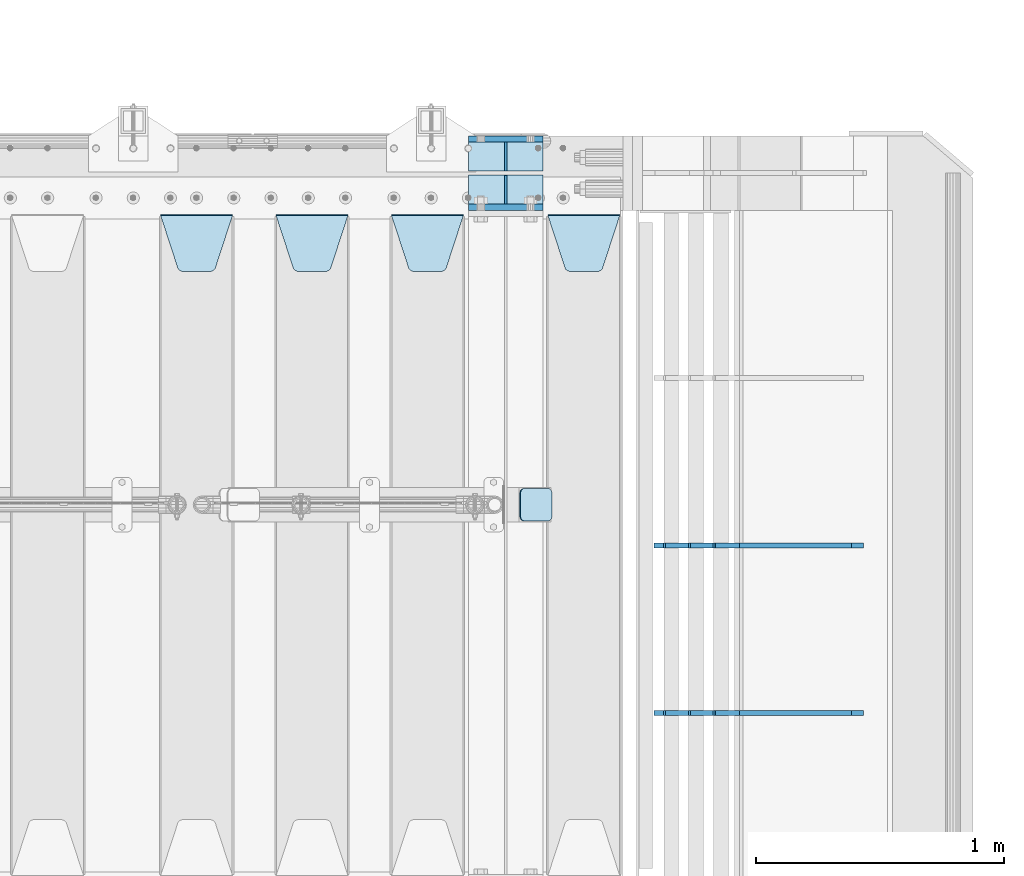
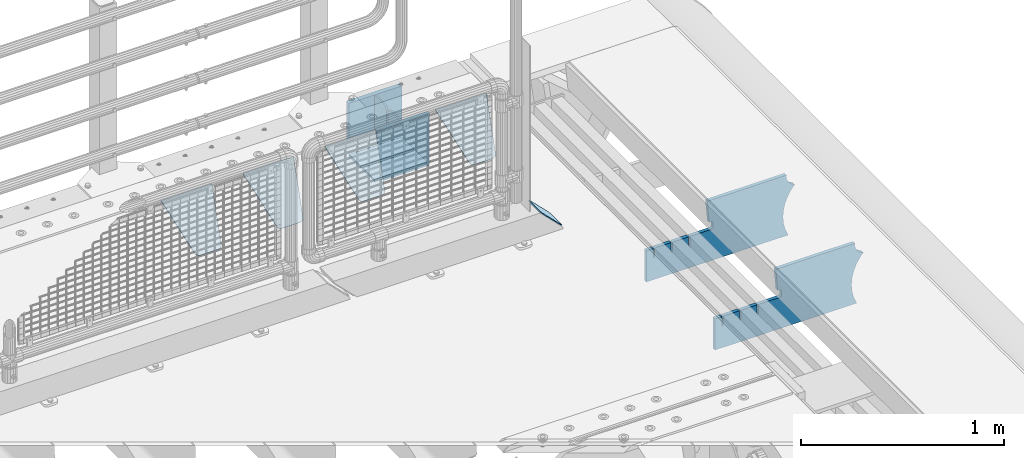
# One storey, part 242 of 257: 13 plates.
"""IFC2X3 building model written with IfcOpenShell, lengths in millimetres."""

from ifc_helpers import new_model, si_unit, frame, origin_with_axes, place, context, subcontext, project, spatial, faceted_brep, material, type_object, element, save


model = new_model("IFC2X3")

# Units and contexts
model_context = context("Model", 3, precision=1e-05, world=origin_with_axes())
body_context = subcontext(model_context, "Body", "Model", "MODEL_VIEW")
ifc_project = project(units=[si_unit("LENGTHUNIT", "METRE", prefix="MILLI"), si_unit("AREAUNIT", "SQUARE_METRE"), si_unit("VOLUMEUNIT", "CUBIC_METRE"), si_unit("MASSUNIT", "GRAM", prefix="KILO"), si_unit("TIMEUNIT", "SECOND"), si_unit("PLANEANGLEUNIT", "RADIAN"), si_unit("SOLIDANGLEUNIT", "STERADIAN"), si_unit("THERMODYNAMICTEMPERATUREUNIT", "DEGREE_CELSIUS"), si_unit("LUMINOUSINTENSITYUNIT", "LUMEN")], contexts=[model_context])

# Site, building, storey
site_placement = place(None, origin_with_axes())
site = spatial("IfcSite", under=ifc_project, at=site_placement, CompositionType="ELEMENT")
building_placement = place(site_placement, origin_with_axes())
building = spatial("IfcBuilding", under=site, at=building_placement, Name="Standard", CompositionType="ELEMENT")
storey_placement = place(building_placement, origin_with_axes())
storey = spatial("IfcBuildingStorey", under=building, at=storey_placement, Name="Undefined", CompositionType="ELEMENT", Elevation=0.0)

# Plates
ifc_material_1 = material(Name="STEEL/S355N")
plate_type_1 = type_object("IfcPlateType", PredefinedType="NOTDEFINED")
for number, where, z_axis, x_axis in (
    (1, (58645.0, 12137.5, -339.999999999993), (0.0, 0.0, 1.0), (1.0, 0.0, 0.0)),
    (2, (58645.0, 11862.5, -339.999999999993), (0.0, 0.0, 1.0), (1.0, 0.0, 0.0)),
):
    element("IfcPlate", number, at=place(storey_placement, frame(where, z_axis=z_axis, x_axis=x_axis)), inside=storey, type_object=plate_type_1, material=ifc_material_1, context=body_context, shape_type="Brep", body=[
        faceted_brep([(0.0, -12.5, 0.0), (0.0, -12.5, 310.0), (0.0, 12.5, 310.0), (0.0, 12.5, 0.0), (300.0, -12.5, 310.0), (300.0, 12.5, 310.0), (300.0, -12.5, 0.0), (300.0, 12.5, 0.0)], [[[0, 1, 2, 3]], [[1, 4, 5, 2]], [[4, 6, 7, 5]], [[6, 0, 3, 7]], [[5, 7, 3, 2]], [[6, 4, 1, 0]]]),
    ])
plate_type_2 = type_object("IfcPlateType", PredefinedType="NOTDEFINED")
for number, where, z_axis, x_axis in (
    (3, (58645.0, 11992.0, -342.999999999993), (0.0, -1.0, 0.0), (1.0, 0.0, 0.0)),
    (4, (58645.0, 12008.0, -342.999999999993), (0.0, 1.0, 0.0), (1.0, 0.0, 0.0)),
):
    element("IfcPlate", number, at=place(storey_placement, frame(where, z_axis=z_axis, x_axis=x_axis)), inside=storey, type_object=plate_type_2, material=ifc_material_1, context=body_context, shape_type="Brep", body=[
        faceted_brep([(0.0, -7.0, 0.0), (0.0, -7.0, 117.0), (0.0, 7.0, 117.0), (0.0, 7.0, 0.0), (300.0, -7.0, 117.0), (300.0, 7.0, 117.0), (300.0, -7.0, 0.0), (300.0, 7.0, 0.0)], [[[0, 1, 2, 3]], [[1, 4, 5, 2]], [[4, 6, 7, 5]], [[6, 0, 3, 7]], [[5, 7, 3, 2]], [[6, 4, 1, 0]]]),
    ])
plate_type_3 = type_object("IfcPlateType", PredefinedType="NOTDEFINED")
for number, where, z_axis, x_axis in (
    (5, (58795.0, 12008.0, -29.999999999993), (0.0, 0.0, -1.0), (0.0, 1.0, 0.0)),
    (6, (58795.0, 11992.0, -29.999999999993), (0.0, 0.0, -1.0), (0.0, -1.0, 0.0)),
):
    element("IfcPlate", number, at=place(storey_placement, frame(where, z_axis=z_axis, x_axis=x_axis)), inside=storey, type_object=plate_type_3, material=ifc_material_1, context=body_context, shape_type="Brep", body=[
        faceted_brep([(0.0, -5.0, 30.0), (0.0, -5.0, 306.0), (0.0, 5.0, 306.0), (0.0, 5.0, 30.0), (117.0, -5.0, 306.0), (117.0, 5.0, 306.0), (117.0, -5.0, 0.0), (117.0, 5.0, 0.0), (30.0, -5.0, 0.0), (30.0, 5.0, 0.0), (24.7905546699922, -5.0, 0.455767409633758), (24.7905546699922, 5.0, 0.455767409633758), (19.7393957002296, -5.0, 1.80922137642275), (19.7393957002296, 5.0, 1.80922137642275), (15.0, -5.0, 4.01923788646684), (15.0, 5.0, 4.01923788646684), (10.7163717094036, -5.0, 7.01866670643066), (10.7163717094036, 5.0, 7.01866670643066), (7.01866670643085, -5.0, 10.7163717094038), (7.01866670643085, 5.0, 10.7163717094038), (4.01923788646673, -5.0, 15.0), (4.01923788646673, 5.0, 15.0), (1.80922137642301, -5.0, 19.7393957002299), (1.80922137642301, 5.0, 19.7393957002299), (0.455767409634063, -5.0, 24.7905546699921), (0.455767409634063, 5.0, 24.7905546699921)], [[[0, 1, 2, 3]], [[1, 4, 5, 2]], [[4, 6, 7, 5]], [[6, 8, 9, 7]], [[8, 10, 11, 9]], [[10, 12, 13, 11]], [[12, 14, 15, 13]], [[14, 16, 17, 15]], [[16, 18, 19, 17]], [[18, 20, 21, 19]], [[20, 22, 23, 21]], [[22, 24, 25, 23]], [[24, 0, 3, 25]], [[5, 7, 9, 11, 13, 15, 17, 19, 21, 23, 25, 3, 2]], [[24, 22, 20, 18, 16, 14, 12, 10, 8, 6, 4, 1, 0]]]),
    ])
plate_type_4 = type_object("IfcPlateType", PredefinedType="NOTDEFINED")
plate_1_placement = place(storey_placement, frame((58965.0, 11831.7677669559, -1.767766952965), z_axis=(0.0, -0.707106781186548, -0.707106781186547), x_axis=(1.0, 0.0, 0.0)))
element("IfcPlate", 7, at=plate_1_placement, inside=storey, type_object=plate_type_4, material=ifc_material_1, context=body_context, shape_type="Brep", body=[
    faceted_brep([(0.0, -2.5, 0.0), (69.345504679477, -2.50000000000091, 300.17173142483), (69.345504679477, 2.5, 300.171731424831), (0.0, 2.5, 0.0), (70.927406119954, -2.50000000000091, 304.8974424154), (70.927406119954, 2.5, 304.8974424154), (73.3818627772271, -2.50000000000091, 309.234538108527), (73.3818627772271, 2.49999999999909, 309.234538108527), (76.6187032999587, -2.5, 313.023683126103), (76.6187032999587, 2.5, 313.023683126103), (80.5190132705029, -2.5, 316.125672595372), (80.5190132705029, 2.5, 316.125672595371), (84.9395038596849, -2.5, 318.426546230476), (84.9395038596849, 2.5, 318.426546230477), (89.7177759439219, -2.5, 319.841774983275), (89.7177759439219, 2.5, 319.841774983275), (94.6782862926484, -2.5, 320.319366455079), (94.6782862926484, 2.5, 320.319366455079), (195.321713707352, -2.5, 320.319366455079), (195.321713707352, 2.5, 320.319366455079), (200.282224056078, -2.5, 319.841774983275), (200.282224056078, 2.49999999999909, 319.841774983275), (205.060496140315, -2.5, 318.426546230476), (205.060496140315, 2.49999999999909, 318.426546230475), (209.480986729497, -2.5, 316.125672595371), (209.480986729497, 2.5, 316.125672595371), (213.381296700041, -2.50000000000091, 313.023683126102), (213.381296700041, 2.5, 313.023683126103), (216.618137222766, -2.50000000000091, 309.234538108527), (216.618137222766, 2.5, 309.234538108527), (219.072593880039, -2.5, 304.897442415399), (219.072593880039, 2.5, 304.897442415399), (220.654495320523, -2.50000000000091, 300.17173142483), (220.654495320523, 2.5, 300.171731424831), (290.0, -2.50000000000091, 0.0), (290.0, 2.5, 9.09494701772928e-13)], [[[0, 1, 2, 3]], [[1, 4, 5, 2]], [[4, 6, 7, 5]], [[6, 8, 9, 7]], [[8, 10, 11, 9]], [[10, 12, 13, 11]], [[12, 14, 15, 13]], [[14, 16, 17, 15]], [[16, 18, 19, 17]], [[18, 20, 21, 19]], [[20, 22, 23, 21]], [[22, 24, 25, 23]], [[24, 26, 27, 25]], [[26, 28, 29, 27]], [[28, 30, 31, 29]], [[30, 32, 33, 31]], [[32, 34, 35, 33]], [[34, 0, 3, 35]], [[5, 7, 9, 11, 13, 15, 17, 19, 21, 23, 25, 27, 29, 31, 33, 35, 3, 2]], [[34, 32, 30, 28, 26, 24, 22, 20, 18, 16, 14, 12, 10, 8, 6, 4, 1, 0]]]),
])
plate_2_placement = place(storey_placement, frame((58335.0, 11831.7677669559, -1.767766952965), z_axis=(0.0, -0.707106781186548, -0.707106781186547), x_axis=(1.0, 0.0, 0.0)))
element("IfcPlate", 8, at=plate_2_placement, inside=storey, type_object=plate_type_4, material=ifc_material_1, context=body_context, shape_type="Brep", body=[
    faceted_brep([(0.0, -2.5, 0.0), (69.345504679477, -2.50000000000091, 300.17173142483), (69.345504679477, 2.5, 300.171731424831), (0.0, 2.5, 0.0), (70.927406119954, -2.50000000000091, 304.8974424154), (70.927406119954, 2.5, 304.8974424154), (73.3818627772271, -2.50000000000091, 309.234538108527), (73.3818627772271, 2.49999999999909, 309.234538108527), (76.6187032999587, -2.5, 313.023683126103), (76.6187032999587, 2.5, 313.023683126103), (80.5190132705029, -2.5, 316.125672595372), (80.5190132705029, 2.5, 316.125672595371), (84.9395038596849, -2.5, 318.426546230476), (84.9395038596849, 2.5, 318.426546230477), (89.7177759439219, -2.5, 319.841774983275), (89.7177759439219, 2.5, 319.841774983275), (94.6782862926484, -2.5, 320.319366455079), (94.6782862926484, 2.5, 320.319366455079), (195.321713707352, -2.5, 320.319366455079), (195.321713707352, 2.5, 320.319366455079), (200.282224056078, -2.5, 319.841774983275), (200.282224056078, 2.49999999999909, 319.841774983275), (205.060496140315, -2.5, 318.426546230476), (205.060496140315, 2.49999999999909, 318.426546230475), (209.480986729497, -2.5, 316.125672595371), (209.480986729497, 2.5, 316.125672595371), (213.381296700041, -2.50000000000091, 313.023683126102), (213.381296700041, 2.5, 313.023683126103), (216.618137222766, -2.50000000000091, 309.234538108527), (216.618137222766, 2.5, 309.234538108527), (219.072593880039, -2.5, 304.897442415399), (219.072593880039, 2.5, 304.897442415399), (220.654495320523, -2.50000000000091, 300.17173142483), (220.654495320523, 2.5, 300.171731424831), (290.0, -2.50000000000091, 0.0), (290.0, 2.5, 9.09494701772928e-13)], [[[0, 1, 2, 3]], [[1, 4, 5, 2]], [[4, 6, 7, 5]], [[6, 8, 9, 7]], [[8, 10, 11, 9]], [[10, 12, 13, 11]], [[12, 14, 15, 13]], [[14, 16, 17, 15]], [[16, 18, 19, 17]], [[18, 20, 21, 19]], [[20, 22, 23, 21]], [[22, 24, 25, 23]], [[24, 26, 27, 25]], [[26, 28, 29, 27]], [[28, 30, 31, 29]], [[30, 32, 33, 31]], [[32, 34, 35, 33]], [[34, 0, 3, 35]], [[5, 7, 9, 11, 13, 15, 17, 19, 21, 23, 25, 27, 29, 31, 33, 35, 3, 2]], [[34, 32, 30, 28, 26, 24, 22, 20, 18, 16, 14, 12, 10, 8, 6, 4, 1, 0]]]),
])
plate_3_placement = place(storey_placement, frame((57870.0, 11831.7677669559, -1.767766952965), z_axis=(0.0, -0.707106781186548, -0.707106781186547), x_axis=(1.0, 0.0, 0.0)))
element("IfcPlate", 9, at=plate_3_placement, inside=storey, type_object=plate_type_4, material=ifc_material_1, context=body_context, shape_type="Brep", body=[
    faceted_brep([(0.0, -2.5, 0.0), (69.345504679477, -2.50000000000091, 300.17173142483), (69.345504679477, 2.5, 300.171731424831), (0.0, 2.5, 0.0), (70.927406119954, -2.50000000000091, 304.8974424154), (70.927406119954, 2.5, 304.8974424154), (73.3818627772271, -2.50000000000091, 309.234538108527), (73.3818627772271, 2.49999999999909, 309.234538108527), (76.6187032999587, -2.5, 313.023683126103), (76.6187032999587, 2.5, 313.023683126103), (80.5190132705029, -2.5, 316.125672595372), (80.5190132705029, 2.5, 316.125672595371), (84.9395038596849, -2.5, 318.426546230476), (84.9395038596849, 2.5, 318.426546230477), (89.7177759439219, -2.5, 319.841774983275), (89.7177759439219, 2.5, 319.841774983275), (94.6782862926484, -2.5, 320.319366455079), (94.6782862926484, 2.5, 320.319366455079), (195.321713707352, -2.5, 320.319366455079), (195.321713707352, 2.5, 320.319366455079), (200.282224056078, -2.5, 319.841774983275), (200.282224056078, 2.49999999999909, 319.841774983275), (205.060496140315, -2.5, 318.426546230476), (205.060496140315, 2.49999999999909, 318.426546230475), (209.480986729497, -2.5, 316.125672595371), (209.480986729497, 2.5, 316.125672595371), (213.381296700041, -2.50000000000091, 313.023683126102), (213.381296700041, 2.5, 313.023683126103), (216.618137222766, -2.50000000000091, 309.234538108527), (216.618137222766, 2.5, 309.234538108527), (219.072593880039, -2.5, 304.897442415399), (219.072593880039, 2.5, 304.897442415399), (220.654495320523, -2.50000000000091, 300.17173142483), (220.654495320523, 2.5, 300.171731424831), (290.0, -2.50000000000091, 0.0), (290.0, 2.5, 9.09494701772928e-13)], [[[0, 1, 2, 3]], [[1, 4, 5, 2]], [[4, 6, 7, 5]], [[6, 8, 9, 7]], [[8, 10, 11, 9]], [[10, 12, 13, 11]], [[12, 14, 15, 13]], [[14, 16, 17, 15]], [[16, 18, 19, 17]], [[18, 20, 21, 19]], [[20, 22, 23, 21]], [[22, 24, 25, 23]], [[24, 26, 27, 25]], [[26, 28, 29, 27]], [[28, 30, 31, 29]], [[30, 32, 33, 31]], [[32, 34, 35, 33]], [[34, 0, 3, 35]], [[5, 7, 9, 11, 13, 15, 17, 19, 21, 23, 25, 27, 29, 31, 33, 35, 3, 2]], [[34, 32, 30, 28, 26, 24, 22, 20, 18, 16, 14, 12, 10, 8, 6, 4, 1, 0]]]),
])
plate_4_placement = place(storey_placement, frame((57405.0, 11831.7677669559, -1.767766952965), z_axis=(0.0, -0.707106781186548, -0.707106781186547), x_axis=(1.0, 0.0, 0.0)))
element("IfcPlate", 10, at=plate_4_placement, inside=storey, type_object=plate_type_4, material=ifc_material_1, context=body_context, shape_type="Brep", body=[
    faceted_brep([(0.0, -2.5, 0.0), (69.345504679477, -2.50000000000091, 300.17173142483), (69.345504679477, 2.5, 300.171731424831), (0.0, 2.5, 0.0), (70.927406119954, -2.50000000000091, 304.8974424154), (70.927406119954, 2.5, 304.8974424154), (73.3818627772271, -2.50000000000091, 309.234538108527), (73.3818627772271, 2.49999999999909, 309.234538108527), (76.6187032999587, -2.5, 313.023683126103), (76.6187032999587, 2.5, 313.023683126103), (80.5190132705029, -2.5, 316.125672595372), (80.5190132705029, 2.5, 316.125672595371), (84.9395038596849, -2.5, 318.426546230476), (84.9395038596849, 2.5, 318.426546230477), (89.7177759439219, -2.5, 319.841774983275), (89.7177759439219, 2.5, 319.841774983275), (94.6782862926484, -2.5, 320.319366455079), (94.6782862926484, 2.5, 320.319366455079), (195.321713707352, -2.5, 320.319366455079), (195.321713707352, 2.5, 320.319366455079), (200.282224056078, -2.5, 319.841774983275), (200.282224056078, 2.49999999999909, 319.841774983275), (205.060496140315, -2.5, 318.426546230476), (205.060496140315, 2.49999999999909, 318.426546230475), (209.480986729497, -2.5, 316.125672595371), (209.480986729497, 2.5, 316.125672595371), (213.381296700041, -2.50000000000091, 313.023683126102), (213.381296700041, 2.5, 313.023683126103), (216.618137222766, -2.50000000000091, 309.234538108527), (216.618137222766, 2.5, 309.234538108527), (219.072593880039, -2.5, 304.897442415399), (219.072593880039, 2.5, 304.897442415399), (220.654495320523, -2.50000000000091, 300.17173142483), (220.654495320523, 2.5, 300.171731424831), (290.0, -2.50000000000091, 0.0), (290.0, 2.5, 9.09494701772928e-13)], [[[0, 1, 2, 3]], [[1, 4, 5, 2]], [[4, 6, 7, 5]], [[6, 8, 9, 7]], [[8, 10, 11, 9]], [[10, 12, 13, 11]], [[12, 14, 15, 13]], [[14, 16, 17, 15]], [[16, 18, 19, 17]], [[18, 20, 21, 19]], [[20, 22, 23, 21]], [[22, 24, 25, 23]], [[24, 26, 27, 25]], [[26, 28, 29, 27]], [[28, 30, 31, 29]], [[30, 32, 33, 31]], [[32, 34, 35, 33]], [[34, 0, 3, 35]], [[5, 7, 9, 11, 13, 15, 17, 19, 21, 23, 25, 27, 29, 31, 33, 35, 3, 2]], [[34, 32, 30, 28, 26, 24, 22, 20, 18, 16, 14, 12, 10, 8, 6, 4, 1, 0]]]),
])
ifc_material_2 = material(Name="STEEL/S355J2")
plate_type_5 = type_object("IfcPlateType", PredefinedType="NOTDEFINED")
plate_5_placement = place(storey_placement, frame((58853.192418479, 10729.5, 166.254400376571), z_axis=(0.707410512925779, 0.0, -0.70680291892584), x_axis=(0.0, -1.0, 0.0)))
element("IfcPlate", 11, at=plate_5_placement, inside=storey, type_object=plate_type_5, material=ifc_material_2, context=body_context, shape_type="Brep", body=[
    faceted_brep([(0.0, -2.49999999999272, 19.9999999999927), (0.0, -2.49999999999272, 158.926651000977), (0.0, 2.50000000001455, 158.926651000969), (0.0, 2.50000000000728, 19.9999999999927), (0.384294391935327, -2.49999999999272, 162.828457441297), (0.384294391935327, 2.50000000000728, 162.828457441297), (1.52240934977453, -2.49999999999272, 166.580319648267), (1.52240934977453, 2.50000000000728, 166.580319648267), (3.37060775394821, -2.5, 170.03805566136), (3.37060775394821, 2.50000000000728, 170.03805566136), (5.85786437626848, -2.49999999999272, 173.068786624703), (5.85786437626848, 2.5, 173.068786624703), (8.88859533960749, -2.49999999999272, 175.556043247016), (8.88859533960749, 2.50000000001455, 175.556043247016), (12.3463313526991, -2.49999999999272, 177.404241651195), (12.3463313526991, 2.50000000000728, 177.404241651195), (16.0981935596774, -2.49999999999272, 178.542356609032), (16.0981935596774, 2.50000000000728, 178.542356609032), (20.0, -2.49999999999272, 178.926651000969), (20.0, 2.50000000000728, 178.926651000969), (110.0, -2.49999999999272, 178.926651000969), (110.0, 2.50000000000728, 178.926651000969), (113.901806440323, -2.49999999999272, 178.542356609032), (113.901806440323, 2.50000000000728, 178.542356609032), (117.653668647301, -2.49999999999272, 177.404241651195), (117.653668647301, 2.50000000000728, 177.404241651195), (121.111404660393, -2.49999999999272, 175.556043247016), (121.111404660393, 2.50000000001455, 175.556043247016), (124.142135623732, -2.49999999999272, 173.068786624703), (124.142135623732, 2.5, 173.068786624703), (126.629392246052, -2.5, 170.03805566136), (126.629392246052, 2.50000000000728, 170.03805566136), (128.477590650225, -2.49999999999272, 166.580319648267), (128.477590650225, 2.50000000000728, 166.580319648267), (129.615705608065, -2.49999999999272, 162.828457441297), (129.615705608065, 2.50000000000728, 162.828457441297), (130.0, -2.49999999999272, 158.926651000977), (130.0, 2.50000000001455, 158.926651000969), (130.0, -2.49999999999272, 19.9999999999927), (130.0, 2.50000000000728, 19.9999999999927), (129.615705608065, -2.49999999999272, 16.0981935596719), (129.615705608065, 2.50000000000728, 16.0981935596719), (128.477590650225, -2.49999999999272, 12.3463313526954), (128.477590650225, 2.50000000000728, 12.3463313526881), (126.629392246052, -2.49999999999272, 8.88859533960203), (126.629392246052, 2.50000000000728, 8.88859533959476), (124.142135623732, -2.49999999999272, 5.85786437626666), (124.142135623732, 2.50000000000728, 5.85786437626666), (121.111404660393, -2.49999999999272, 3.37060775394639), (121.111404660393, 2.50000000000728, 3.37060775393911), (117.653668647301, -2.49999999999272, 1.52240934976726), (117.653668647301, 2.50000000000728, 1.52240934977453), (113.901806440323, -2.49999999999272, 0.38429439192987), (113.901806440323, 2.50000000000728, 0.38429439192987), (110.0, -2.49999999999272, -7.27595761418343e-12), (110.0, 2.50000000000728, -7.27595761418343e-12), (20.0, -2.49999999999272, -7.27595761418343e-12), (20.0, 2.50000000000728, -7.27595761418343e-12), (16.0981935596774, -2.49999999999272, 0.38429439192987), (16.0981935596774, 2.50000000000728, 0.38429439192987), (12.3463313526991, -2.49999999999272, 1.52240934976726), (12.3463313526991, 2.50000000000728, 1.52240934977453), (8.88859533960749, -2.49999999999272, 3.37060775394639), (8.88859533960749, 2.50000000000728, 3.37060775393911), (5.85786437626848, -2.49999999999272, 5.85786437626666), (5.85786437626848, 2.50000000000728, 5.85786437626666), (3.37060775394821, -2.49999999999272, 8.88859533960203), (3.37060775394821, 2.50000000000728, 8.88859533959476), (1.52240934977453, -2.49999999999272, 12.3463313526881), (1.52240934977453, 2.50000000000728, 12.3463313526881), (0.384294391935327, -2.49999999999272, 16.0981935596719), (0.384294391935327, 2.50000000000728, 16.0981935596719)], [[[0, 1, 2, 3]], [[1, 4, 5, 2]], [[4, 6, 7, 5]], [[6, 8, 9, 7]], [[8, 10, 11, 9]], [[10, 12, 13, 11]], [[12, 14, 15, 13]], [[14, 16, 17, 15]], [[16, 18, 19, 17]], [[18, 20, 21, 19]], [[20, 22, 23, 21]], [[22, 24, 25, 23]], [[24, 26, 27, 25]], [[26, 28, 29, 27]], [[28, 30, 31, 29]], [[30, 32, 33, 31]], [[32, 34, 35, 33]], [[34, 36, 37, 35]], [[36, 38, 39, 37]], [[38, 40, 41, 39]], [[40, 42, 43, 41]], [[42, 44, 45, 43]], [[44, 46, 47, 45]], [[46, 48, 49, 47]], [[48, 50, 51, 49]], [[50, 52, 53, 51]], [[52, 54, 55, 53]], [[54, 56, 57, 55]], [[56, 58, 59, 57]], [[58, 60, 61, 59]], [[60, 62, 63, 61]], [[62, 64, 65, 63]], [[64, 66, 67, 65]], [[66, 68, 69, 67]], [[68, 70, 71, 69]], [[70, 0, 3, 71]], [[5, 7, 9, 11, 13, 15, 17, 19, 21, 23, 25, 27, 29, 31, 33, 35, 37, 39, 41, 43, 45, 47, 49, 51, 53, 55, 57, 59, 61, 63, 65, 67, 69, 71, 3, 2]], [[70, 68, 66, 64, 62, 60, 58, 56, 54, 52, 50, 48, 46, 44, 42, 40, 38, 36, 34, 32, 30, 28, 26, 24, 22, 20, 18, 16, 14, 12, 10, 8, 6, 4, 1, 0]]]),
])
plate_type_6 = type_object("IfcPlateType", PredefinedType="NOTDEFINED")
plate_6_placement = place(storey_placement, frame((60232.9182339676, 9824.99928283691, -374.002067436516), z_axis=(0.0, 0.0, 1.0), x_axis=(-1.0, 0.0, 0.0)))
element("IfcPlate", 12, at=plate_6_placement, inside=storey, type_object=plate_type_6, material=ifc_material_1, context=body_context, shape_type="Brep", body=[
    faceted_brep([(801.919404066546, -10.0, 188.0), (801.919404066546, 10.0, 188.0), (801.919404066546, 10.0, 132.002067436952), (801.919404066546, -10.0, 132.002067436952), (793.919404066546, 10.0, 132.002067436952), (793.919404066546, -10.0, 132.002067436952), (793.919404066546, 10.0, 180.002067436952), (793.919404066546, -10.0, 180.002067436952), (793.52785619691, 10.0, 182.474203391951), (793.52785619691, -10.0, 182.474203391951), (792.391540021548, 10.0, 184.704349455291), (792.391540021548, -10.0, 184.704349455291), (790.621686084887, 10.0, 186.474203391951), (790.621686084887, -10.0, 186.474203391951), (788.391540021548, 10.0, 187.610519567313), (788.391540021548, -10.0, 187.610519567313), (785.919404066546, -10.0, 188.002067436952), (785.919404066546, 10.0, 188.0), (841.0, -10.0, 188.0), (841.0, -10.0, 0.0), (841.0, 10.0, 0.0), (841.0, 10.0, 188.0), (33.3619566735943, -10.0, 0.0), (33.3619566735943, 10.0, 0.0), (36.2350612208102, -10.0, 4.68848050267013), (36.2350612208102, 10.0, 4.68848050267013), (51.4877592159319, -10.0, 41.5117508652784), (51.4877592159319, 10.0, 41.5117508652784), (60.7922425881334, -10.0, 80.2677133162964), (60.7922425881334, 10.0, 80.2677133162964), (63.9194040769653, -10.0, 120.002067436515), (63.9194040769653, 10.0, 120.002067436515), (60.7922425881334, -10.0, 159.736421556734), (60.7922425881334, 10.0, 159.736421556734), (51.4877592159319, -10.0, 198.492384007752), (51.4877592159319, 10.0, 198.492384007752), (36.2350612208102, -10.0, 235.31565437036), (36.2350612208102, 10.0, 235.31565437036), (15.4097206482038, -10.0, 269.299521518803), (15.4097206482038, 10.0, 269.299521518803), (-3.35474438100209, -10.0, 291.269887256574), (-3.35474438100209, 10.0, 291.269887256574), (-2.36881039375294, -10.0000000000001, 291.426043859339), (-2.36881039375294, 10.0, 291.426043859339), (17.1449676604752, -10.0000000000001, 301.368810393754), (17.1449676604752, 10.0, 301.368810393754), (32.6311896062471, -10.0000000000001, 316.855032339527), (32.6311896062471, 10.0, 316.855032339527), (42.573956140659, -10.0000000000001, 336.368810393754), (42.573956140659, 10.0, 336.368810393754), (46.0, -10.0000000000001, 358.0), (46.0, 10.0, 358.0), (45.0495205499174, -10.0, 364.001091067617), (45.0495205499174, 10.0, 364.001091067617), (495.040008544922, -10.0, 364.010009765625), (495.040008544922, 10.0, 364.010009765625), (483.600036621094, -10.0, 233.759994506836), (483.600036621094, 10.0, 233.759994506836), (472.0, -10.0, 233.759994506836), (472.0, 10.0, 233.759994506836), (468.909830056247, -10.0, 233.270559669787), (468.909830056247, 10.0, 233.270559669787), (466.122147477072, -10.0, 231.850164450585), (466.122147477072, 10.0, 231.850164450585), (463.909830056247, -10.0, 229.637847029761), (463.909830056247, 10.0, 229.637847029761), (462.489434837051, -10.0, 226.850164450585), (462.489434837051, 10.0, 226.850164450585), (462.0, -10.0, 223.759994506836), (462.0, 10.0, 223.759994506836), (462.0, -10.0, 198.0), (462.0, 10.0, 198.0), (462.489434837051, -10.0, 194.909830056251), (462.489434837051, 10.0, 194.909830056251), (463.909830056247, -10.0, 192.122147477075), (463.909830056247, 10.0, 192.122147477075), (466.122147477072, -10.0, 189.909830056251), (466.122147477072, 10.0, 189.909830056251), (468.909830056247, -10.0, 188.489434837048), (468.909830056247, 10.0, 188.489434837048), (472.0, -10.0, 188.0), (472.0, 10.0, 188.0), (585.919404066546, -10.0, 188.002067436952), (585.919404066546, 10.0, 188.0), (588.391540021548, -10.0, 187.610519567313), (588.391540021548, 10.0, 187.610519567313), (590.621686084887, -10.0, 186.474203391951), (590.621686084887, 10.0, 186.474203391951), (592.391540021548, -10.0, 184.704349455291), (592.391540021548, 10.0, 184.704349455291), (593.52785619691, -10.0, 182.474203391951), (593.52785619691, 10.0, 182.474203391951), (593.919404066546, -10.0, 180.002067436952), (593.919404066546, 10.0, 180.002067436952), (593.919404066546, -10.0, 132.002067436952), (593.919404066546, 10.0, 132.002067436952), (601.919404066546, -10.0, 132.002067436952), (601.919404066546, 10.0, 132.002067436952), (601.919404066546, -10.0, 188.0), (601.919404066546, 10.0, 188.0), (685.919404066546, -10.0, 188.002067436952), (685.919404066546, 10.0, 188.0), (688.391540021548, -9.99999999999977, 187.610519567313), (688.391540021548, 10.0, 187.610519567313), (690.621686084887, -9.99999999999977, 186.474203391951), (690.621686084887, 10.0, 186.474203391951), (692.391540021548, -9.99999999999977, 184.704349455291), (692.391540021548, 10.0, 184.704349455291), (693.52785619691, -9.99999999999977, 182.474203391951), (693.52785619691, 10.0, 182.474203391951), (693.919404066546, -9.99999999999977, 180.002067436952), (693.919404066546, 10.0, 180.002067436952), (693.919404066546, -9.99999999999977, 132.002067436952), (693.919404066546, 10.0, 132.002067436952), (701.919404066546, -9.99999999999977, 132.002067436952), (701.919404066546, 10.0, 132.002067436952), (701.919404066546, -10.0, 188.0), (701.919404066546, 10.0, 188.0)], [[[0, 1, 2, 3]], [[3, 2, 4, 5]], [[5, 4, 6, 7]], [[7, 6, 8, 9]], [[9, 8, 10, 11]], [[11, 10, 12, 13]], [[13, 12, 14, 15]], [[16, 15, 14, 17]], [[18, 19, 20, 21]], [[20, 19, 22, 23]], [[22, 24, 25, 23]], [[26, 27, 25, 24]], [[28, 29, 27, 26]], [[30, 31, 29, 28]], [[32, 33, 31, 30]], [[34, 35, 33, 32]], [[36, 37, 35, 34]], [[38, 39, 37, 36]], [[39, 38, 40, 41]], [[40, 42, 43, 41]], [[44, 45, 43, 42]], [[46, 47, 45, 44]], [[48, 49, 47, 46]], [[50, 51, 49, 48]], [[52, 53, 51, 50]], [[54, 55, 53, 52]], [[54, 56, 57, 55]], [[56, 58, 59, 57]], [[58, 60, 61, 59]], [[60, 62, 63, 61]], [[62, 64, 65, 63]], [[64, 66, 67, 65]], [[66, 68, 69, 67]], [[68, 70, 71, 69]], [[70, 72, 73, 71]], [[72, 74, 75, 73]], [[74, 76, 77, 75]], [[76, 78, 79, 77]], [[78, 80, 81, 79]], [[81, 80, 82, 83]], [[82, 84, 85, 83]], [[86, 87, 85, 84]], [[88, 89, 87, 86]], [[90, 91, 89, 88]], [[92, 93, 91, 90]], [[94, 95, 93, 92]], [[96, 97, 95, 94]], [[98, 99, 97, 96]], [[99, 98, 100, 101]], [[100, 102, 103, 101]], [[104, 105, 103, 102]], [[106, 107, 105, 104]], [[108, 109, 107, 106]], [[110, 111, 109, 108]], [[112, 113, 111, 110]], [[114, 115, 113, 112]], [[116, 117, 115, 114]], [[117, 116, 16, 17]], [[12, 10, 8, 6, 4, 2, 1, 21, 20, 23, 25, 27, 29, 31, 33, 35, 37, 39, 41, 43, 45, 47, 49, 51, 53, 55, 57, 59, 61, 63, 65, 67, 69, 71, 73, 75, 77, 79, 81, 83, 85, 87, 89, 91, 93, 95, 97, 99, 101, 103, 105, 107, 109, 111, 113, 115, 117, 17, 14]], [[18, 21, 1, 0]], [[116, 114, 112, 110, 108, 106, 104, 102, 100, 98, 96, 94, 92, 90, 88, 86, 84, 82, 80, 78, 76, 74, 72, 70, 68, 66, 64, 62, 60, 58, 56, 54, 52, 50, 48, 46, 44, 42, 40, 38, 36, 34, 32, 30, 28, 26, 24, 22, 19, 18, 0, 3, 5, 7, 9, 11, 13, 15, 16]]]),
])
plate_7_placement = place(storey_placement, frame((60232.9182339676, 10499.9992828369, -374.002067436516), z_axis=(0.0, 0.0, 1.0), x_axis=(-1.0, 0.0, 0.0)))
element("IfcPlate", 13, at=plate_7_placement, inside=storey, type_object=plate_type_6, material=ifc_material_1, context=body_context, shape_type="Brep", body=[
    faceted_brep([(801.919404066546, -10.0, 188.0), (801.919404066546, 10.0, 188.0), (801.919404066546, 10.0, 132.002067436952), (801.919404066546, -10.0, 132.002067436952), (793.919404066546, 10.0, 132.002067436952), (793.919404066546, -10.0, 132.002067436952), (793.919404066546, 10.0, 180.002067436952), (793.919404066546, -10.0, 180.002067436952), (793.52785619691, 10.0, 182.474203391951), (793.52785619691, -10.0, 182.474203391951), (792.391540021548, 10.0, 184.704349455291), (792.391540021548, -10.0, 184.704349455291), (790.621686084887, 10.0, 186.474203391951), (790.621686084887, -10.0, 186.474203391951), (788.391540021548, 10.0, 187.610519567313), (788.391540021548, -10.0, 187.610519567313), (785.919404066546, -10.0, 188.002067436952), (785.919404066546, 10.0, 188.0), (841.0, -10.0, 188.0), (841.0, -10.0, 0.0), (841.0, 10.0, 0.0), (841.0, 10.0, 188.0), (33.3619566735943, -10.0, 0.0), (33.3619566735943, 10.0, 0.0), (36.2350612208102, -10.0, 4.68848050267013), (36.2350612208102, 10.0, 4.68848050267013), (51.4877592159319, -10.0, 41.5117508652784), (51.4877592159319, 10.0, 41.5117508652784), (60.7922425881334, -10.0, 80.2677133162964), (60.7922425881334, 10.0, 80.2677133162964), (63.9194040769653, -10.0, 120.002067436515), (63.9194040769653, 10.0, 120.002067436515), (60.7922425881334, -10.0, 159.736421556734), (60.7922425881334, 10.0, 159.736421556734), (51.4877592159319, -10.0, 198.492384007752), (51.4877592159319, 10.0, 198.492384007752), (36.2350612208102, -10.0, 235.31565437036), (36.2350612208102, 10.0, 235.31565437036), (15.4097206482038, -10.0, 269.299521518803), (15.4097206482038, 10.0, 269.299521518803), (-3.35474438100209, -10.0, 291.269887256574), (-3.35474438100209, 10.0, 291.269887256574), (-2.36881039375294, -10.0000000000001, 291.426043859339), (-2.36881039375294, 10.0, 291.426043859339), (17.1449676604752, -10.0000000000001, 301.368810393754), (17.1449676604752, 10.0, 301.368810393754), (32.6311896062471, -10.0000000000001, 316.855032339527), (32.6311896062471, 10.0, 316.855032339527), (42.573956140659, -10.0000000000001, 336.368810393754), (42.573956140659, 10.0, 336.368810393754), (46.0, -10.0000000000001, 358.0), (46.0, 10.0, 358.0), (45.0495205499174, -10.0, 364.001091067617), (45.0495205499174, 10.0, 364.001091067617), (495.040008544922, -10.0, 364.010009765625), (495.040008544922, 10.0, 364.010009765625), (483.600036621094, -10.0, 233.759994506836), (483.600036621094, 10.0, 233.759994506836), (472.0, -10.0, 233.759994506836), (472.0, 10.0, 233.759994506836), (468.909830056247, -10.0, 233.270559669787), (468.909830056247, 10.0, 233.270559669787), (466.122147477072, -10.0, 231.850164450585), (466.122147477072, 10.0, 231.850164450585), (463.909830056247, -10.0, 229.637847029761), (463.909830056247, 10.0, 229.637847029761), (462.489434837051, -10.0, 226.850164450585), (462.489434837051, 10.0, 226.850164450585), (462.0, -10.0, 223.759994506836), (462.0, 10.0, 223.759994506836), (462.0, -10.0, 198.0), (462.0, 10.0, 198.0), (462.489434837051, -10.0, 194.909830056251), (462.489434837051, 10.0, 194.909830056251), (463.909830056247, -10.0, 192.122147477075), (463.909830056247, 10.0, 192.122147477075), (466.122147477072, -10.0, 189.909830056251), (466.122147477072, 10.0, 189.909830056251), (468.909830056247, -10.0, 188.489434837048), (468.909830056247, 10.0, 188.489434837048), (472.0, -10.0, 188.0), (472.0, 10.0, 188.0), (585.919404066546, -10.0, 188.002067436952), (585.919404066546, 10.0, 188.0), (588.391540021548, -10.0, 187.610519567313), (588.391540021548, 10.0, 187.610519567313), (590.621686084887, -10.0, 186.474203391951), (590.621686084887, 10.0, 186.474203391951), (592.391540021548, -10.0, 184.704349455291), (592.391540021548, 10.0, 184.704349455291), (593.52785619691, -10.0, 182.474203391951), (593.52785619691, 10.0, 182.474203391951), (593.919404066546, -10.0, 180.002067436952), (593.919404066546, 10.0, 180.002067436952), (593.919404066546, -10.0, 132.002067436952), (593.919404066546, 10.0, 132.002067436952), (601.919404066546, -10.0, 132.002067436952), (601.919404066546, 10.0, 132.002067436952), (601.919404066546, -10.0, 188.0), (601.919404066546, 10.0, 188.0), (685.919404066546, -10.0, 188.002067436952), (685.919404066546, 10.0, 188.0), (688.391540021548, -9.99999999999977, 187.610519567313), (688.391540021548, 10.0, 187.610519567313), (690.621686084887, -9.99999999999977, 186.474203391951), (690.621686084887, 10.0, 186.474203391951), (692.391540021548, -9.99999999999977, 184.704349455291), (692.391540021548, 10.0, 184.704349455291), (693.52785619691, -9.99999999999977, 182.474203391951), (693.52785619691, 10.0, 182.474203391951), (693.919404066546, -9.99999999999977, 180.002067436952), (693.919404066546, 10.0, 180.002067436952), (693.919404066546, -9.99999999999977, 132.002067436952), (693.919404066546, 10.0, 132.002067436952), (701.919404066546, -9.99999999999977, 132.002067436952), (701.919404066546, 10.0, 132.002067436952), (701.919404066546, -10.0, 188.0), (701.919404066546, 10.0, 188.0)], [[[0, 1, 2, 3]], [[3, 2, 4, 5]], [[5, 4, 6, 7]], [[7, 6, 8, 9]], [[9, 8, 10, 11]], [[11, 10, 12, 13]], [[13, 12, 14, 15]], [[16, 15, 14, 17]], [[18, 19, 20, 21]], [[20, 19, 22, 23]], [[22, 24, 25, 23]], [[26, 27, 25, 24]], [[28, 29, 27, 26]], [[30, 31, 29, 28]], [[32, 33, 31, 30]], [[34, 35, 33, 32]], [[36, 37, 35, 34]], [[38, 39, 37, 36]], [[39, 38, 40, 41]], [[40, 42, 43, 41]], [[44, 45, 43, 42]], [[46, 47, 45, 44]], [[48, 49, 47, 46]], [[50, 51, 49, 48]], [[52, 53, 51, 50]], [[54, 55, 53, 52]], [[54, 56, 57, 55]], [[56, 58, 59, 57]], [[58, 60, 61, 59]], [[60, 62, 63, 61]], [[62, 64, 65, 63]], [[64, 66, 67, 65]], [[66, 68, 69, 67]], [[68, 70, 71, 69]], [[70, 72, 73, 71]], [[72, 74, 75, 73]], [[74, 76, 77, 75]], [[76, 78, 79, 77]], [[78, 80, 81, 79]], [[81, 80, 82, 83]], [[82, 84, 85, 83]], [[86, 87, 85, 84]], [[88, 89, 87, 86]], [[90, 91, 89, 88]], [[92, 93, 91, 90]], [[94, 95, 93, 92]], [[96, 97, 95, 94]], [[98, 99, 97, 96]], [[99, 98, 100, 101]], [[100, 102, 103, 101]], [[104, 105, 103, 102]], [[106, 107, 105, 104]], [[108, 109, 107, 106]], [[110, 111, 109, 108]], [[112, 113, 111, 110]], [[114, 115, 113, 112]], [[116, 117, 115, 114]], [[117, 116, 16, 17]], [[12, 10, 8, 6, 4, 2, 1, 21, 20, 23, 25, 27, 29, 31, 33, 35, 37, 39, 41, 43, 45, 47, 49, 51, 53, 55, 57, 59, 61, 63, 65, 67, 69, 71, 73, 75, 77, 79, 81, 83, 85, 87, 89, 91, 93, 95, 97, 99, 101, 103, 105, 107, 109, 111, 113, 115, 117, 17, 14]], [[18, 21, 1, 0]], [[116, 114, 112, 110, 108, 106, 104, 102, 100, 98, 96, 94, 92, 90, 88, 86, 84, 82, 80, 78, 76, 74, 72, 70, 68, 66, 64, 62, 60, 58, 56, 54, 52, 50, 48, 46, 44, 42, 40, 38, 36, 34, 32, 30, 28, 26, 24, 22, 19, 18, 0, 3, 5, 7, 9, 11, 13, 15, 16]]]),
])

save(model, "model.ifc")
